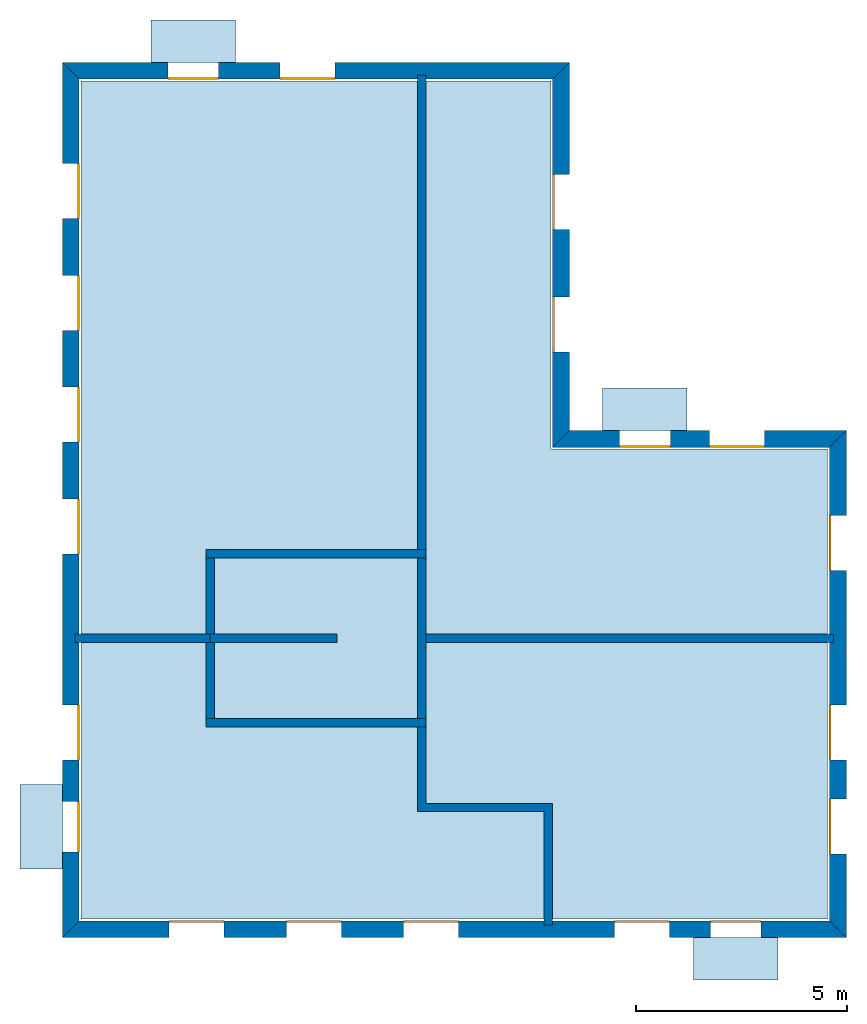
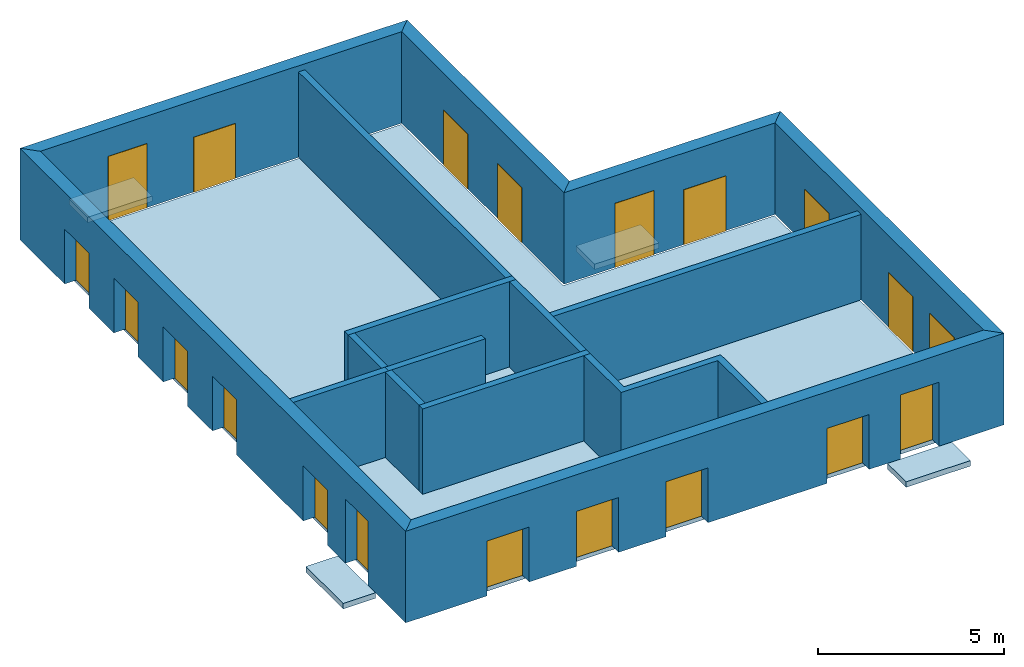
# One storey: 20 windows, 15 walls, 5 slabs, 20 openings.
"""IFC4 building model written with IfcOpenShell, lengths in metres."""

from ifc_helpers import new_model, si_unit, frame, origin_with_axes, place, context, subcontext, project, spatial, line, indexed_curve, outline, extrude, element, fill, save


model = new_model("IFC4")

# Units and contexts
model_context = context("Model", 3, precision=1e-05, world=origin_with_axes())
body_context = subcontext(model_context, "Body", "Model", "MODEL_VIEW")
ifc_project = project(units=[si_unit("AREAUNIT", "SQUARE_METRE"), si_unit("VOLUMEUNIT", "CUBIC_METRE"), si_unit("LENGTHUNIT", "METRE")], contexts=[model_context])

# Site, building, storey
site = spatial("IfcSite", under=ifc_project)
building = spatial("IfcBuilding", under=site, Name="Building 2")
storey_placement = place(None, frame((0.0, 0.0, 4.0), z_axis=(0.0, 0.0, 1.0), x_axis=(1.0, 0.0, 0.0)))
storey = spatial("IfcBuildingStorey", under=building, at=storey_placement, Name="02 Storey")

# Slabs
slab_1_placement = place(storey_placement, origin_with_axes())
element("IfcSlab", 1, at=slab_1_placement, inside=storey, Name="Slab", context=body_context, shape_type="SweptSolid", body=[
    extrude(outline(indexed_curve([(22.099464, -3.599175), (15.553354, -3.599175), (15.553354, 5.1082), (4.433354, 5.1082), (4.433354, -14.719175), (22.099464, -14.719175)], segments=[line(1, 2), line(2, 3), line(3, 4), line(4, 5), line(5, 6)])), origin_with_axes(), (0.0, 0.0, -1.0), 0.2),
])
slab_2_placement = place(storey_placement, origin_with_axes())
element("IfcSlab", 2, at=slab_2_placement, inside=storey, Name="Balcony", context=body_context, shape_type="SweptSolid", body=[
    extrude(outline(indexed_curve([(6.093354, 5.5482), (6.093354, 6.5482), (8.093354, 6.5482), (8.093354, 5.5482)], segments=[line(1, 2), line(2, 3), line(3, 4)])), origin_with_axes(), (0.0, 0.0, -1.0), 0.18),
])
slab_3_placement = place(storey_placement, origin_with_axes())
element("IfcSlab", 3, at=slab_3_placement, inside=storey, Name="Balcony", context=body_context, shape_type="SweptSolid", body=[
    extrude(outline(indexed_curve([(16.7753906666667, -3.159175), (16.7753906666667, -2.159175), (18.7753906666667, -2.159175), (18.7753906666667, -3.159175)], segments=[line(1, 2), line(2, 3), line(3, 4)])), origin_with_axes(), (0.0, 0.0, -1.0), 0.18),
])
slab_4_placement = place(storey_placement, origin_with_axes())
element("IfcSlab", 4, at=slab_4_placement, inside=storey, Name="Balcony", context=body_context, shape_type="SweptSolid", body=[
    extrude(outline(indexed_curve([(20.924094, -15.159175), (20.924094, -16.159175), (18.924094, -16.159175), (18.924094, -15.159175)], segments=[line(1, 2), line(2, 3), line(3, 4)])), origin_with_axes(), (0.0, 0.0, -1.0), 0.18),
])
slab_5_placement = place(storey_placement, origin_with_axes())
element("IfcSlab", 5, at=slab_5_placement, inside=storey, Name="Balcony", context=body_context, shape_type="SweptSolid", body=[
    extrude(outline(indexed_curve([(3.993354, -13.5322976666667), (2.993354, -13.5322976666667), (2.993354, -11.5322976666667), (3.993354, -11.5322976666667)], segments=[line(1, 2), line(2, 3), line(3, 4)])), origin_with_axes(), (0.0, 0.0, -1.0), 0.18),
])

# Walls
wall_1_placement = place(storey_placement, origin_with_axes())
element("IfcWall", 6, at=wall_1_placement, inside=storey, Name="Wall", context=body_context, shape_type="SweptSolid", body=[
    extrude(outline(indexed_curve([(7.593354, -7.978543), (4.293354, -7.978543), (4.293354, -8.178543), (7.593354, -8.178543)], segments=[line(1, 2), line(2, 3), line(3, 4)])), origin_with_axes(), (0.0, 0.0, 1.0), 2.8),
])
wall_2_placement = place(storey_placement, origin_with_axes())
element("IfcWall", 7, at=wall_2_placement, inside=storey, Name="Wall", context=body_context, shape_type="SweptSolid", body=[
    extrude(outline(indexed_curve([(12.593354, 5.2482), (12.393354, 5.2482), (12.393354, -6.178543), (12.593354, -6.178543)], segments=[line(1, 2), line(2, 3), line(3, 4)])), origin_with_axes(), (0.0, 0.0, 1.0), 2.8),
])
wall_3_placement = place(storey_placement, origin_with_axes())
element("IfcWall", 8, at=wall_3_placement, inside=storey, Name="Wall", context=body_context, shape_type="SweptSolid", body=[
    extrude(outline(indexed_curve([(22.239464, -7.978543), (12.393354, -7.978543), (12.393354, -8.178543), (22.239464, -8.178543)], segments=[line(1, 2), line(2, 3), line(3, 4)])), origin_with_axes(), (0.0, 0.0, 1.0), 2.8),
])
wall_4_placement = place(storey_placement, origin_with_axes())
element("IfcWall", 9, at=wall_4_placement, inside=storey, Name="Wall", context=body_context, shape_type="SweptSolid", body=[
    extrude(outline(indexed_curve([(15.593354, -11.978543), (12.593354, -11.978543), (12.593354, -9.978543), (12.393354, -9.978543), (12.393354, -12.178543), (15.393354, -12.178543), (15.393354, -14.859175), (15.593354, -14.859175)], segments=[line(1, 2), line(2, 3), line(3, 4), line(4, 5), line(5, 6), line(6, 7), line(7, 8)])), origin_with_axes(), (0.0, 0.0, 1.0), 2.8),
])

# Wall, openings, windows
wall_5_placement = place(storey_placement, origin_with_axes())
wall_5 = element("IfcWall", 10, at=wall_5_placement, inside=storey, Name="Facade", context=body_context, shape_type="SweptSolid", body=[
    extrude(outline(indexed_curve([(22.139464, -3.559175), (15.593354, -3.559175), (15.993354, -3.159175), (22.539464, -3.159175)], segments=[line(1, 2), line(2, 3), line(3, 4)])), origin_with_axes(), (0.0, 0.0, 1.0), 3.0),
])
opening_1_placement = place(wall_5_placement, origin_with_axes())
opening_1 = element("IfcOpeningElement", 11, at=opening_1_placement, cuts=wall_5, Name="Opening", context=body_context, shape_type="SweptSolid", body=[
    extrude(outline(indexed_curve([(20.6074273333333, -3.119175), (20.6074273333333, -3.619175), (19.3074273333333, -3.619175), (19.3074273333333, -3.119175)], segments=[line(1, 2), line(2, 3), line(3, 4)])), origin_with_axes(), (0.0, 0.0, 1.0), 1.8),
])
opening_2_placement = place(wall_5_placement, origin_with_axes())
opening_2 = element("IfcOpeningElement", 12, at=opening_2_placement, cuts=wall_5, Name="Opening", context=body_context, shape_type="SweptSolid", body=[
    extrude(outline(indexed_curve([(18.3753906666667, -3.119175), (18.3753906666667, -3.619175), (17.1753906666667, -3.619175), (17.1753906666667, -3.119175)], segments=[line(1, 2), line(2, 3), line(3, 4)])), origin_with_axes(), (0.0, 0.0, 1.0), 2.1),
])
window_1_placement = place(storey_placement, origin_with_axes())
window_1 = element("IfcWindow", 13, at=window_1_placement, inside=storey, Name="Window", PredefinedType="WINDOW", context=body_context, shape_type="SweptSolid", body=[
    extrude(outline(indexed_curve([(20.6074273333333, -3.519175), (20.6074273333333, -3.569175), (19.3074273333333, -3.569175), (19.3074273333333, -3.519175)], segments=[line(1, 2), line(2, 3), line(3, 4)])), origin_with_axes(), (0.0, 0.0, 1.0), 1.8),
])
fill(opening_1, window_1)
window_2_placement = place(storey_placement, origin_with_axes())
window_2 = element("IfcWindow", 14, at=window_2_placement, inside=storey, Name="Window", PredefinedType="WINDOW", context=body_context, shape_type="SweptSolid", body=[
    extrude(outline(indexed_curve([(18.3753906666667, -3.519175), (18.3753906666667, -3.569175), (17.1753906666667, -3.569175), (17.1753906666667, -3.519175)], segments=[line(1, 2), line(2, 3), line(3, 4)])), origin_with_axes(), (0.0, 0.0, 1.0), 2.1),
])
fill(opening_2, window_2)

wall_6_placement = place(storey_placement, origin_with_axes())
wall_6 = element("IfcWall", 15, at=wall_6_placement, inside=storey, Name="Facade", context=body_context, shape_type="SweptSolid", body=[
    extrude(outline(indexed_curve([(15.593354, -3.559175), (15.593354, 5.1482), (15.993354, 5.5482), (15.993354, -3.159175)], segments=[line(1, 2), line(2, 3), line(3, 4)])), origin_with_axes(), (0.0, 0.0, 1.0), 3.0),
])
opening_3_placement = place(wall_6_placement, origin_with_axes())
opening_3 = element("IfcOpeningElement", 16, at=opening_3_placement, cuts=wall_6, Name="Opening", context=body_context, shape_type="SweptSolid", body=[
    extrude(outline(indexed_curve([(16.033354, -1.30671666666667), (15.533354, -1.30671666666667), (15.533354, -0.00671666666666659), (16.033354, -0.00671666666666659)], segments=[line(1, 2), line(2, 3), line(3, 4)])), origin_with_axes(), (0.0, 0.0, 1.0), 1.8),
])
opening_4_placement = place(wall_6_placement, origin_with_axes())
opening_4 = element("IfcOpeningElement", 17, at=opening_4_placement, cuts=wall_6, Name="Opening", context=body_context, shape_type="SweptSolid", body=[
    extrude(outline(indexed_curve([(16.033354, 1.59574166666667), (15.533354, 1.59574166666667), (15.533354, 2.89574166666667), (16.033354, 2.89574166666667)], segments=[line(1, 2), line(2, 3), line(3, 4)])), origin_with_axes(), (0.0, 0.0, 1.0), 1.8),
])
window_3_placement = place(storey_placement, origin_with_axes())
window_3 = element("IfcWindow", 18, at=window_3_placement, inside=storey, Name="Window", PredefinedType="WINDOW", context=body_context, shape_type="SweptSolid", body=[
    extrude(outline(indexed_curve([(15.633354, -1.30671666666667), (15.583354, -1.30671666666667), (15.583354, -0.00671666666666659), (15.633354, -0.00671666666666659)], segments=[line(1, 2), line(2, 3), line(3, 4)])), origin_with_axes(), (0.0, 0.0, 1.0), 1.8),
])
fill(opening_3, window_3)
window_4_placement = place(storey_placement, origin_with_axes())
window_4 = element("IfcWindow", 19, at=window_4_placement, inside=storey, Name="Window", PredefinedType="WINDOW", context=body_context, shape_type="SweptSolid", body=[
    extrude(outline(indexed_curve([(15.633354, 1.59574166666667), (15.583354, 1.59574166666667), (15.583354, 2.89574166666667), (15.633354, 2.89574166666667)], segments=[line(1, 2), line(2, 3), line(3, 4)])), origin_with_axes(), (0.0, 0.0, 1.0), 1.8),
])
fill(opening_4, window_4)

wall_7_placement = place(storey_placement, origin_with_axes())
wall_7 = element("IfcWall", 20, at=wall_7_placement, inside=storey, Name="Facade", context=body_context, shape_type="SweptSolid", body=[
    extrude(outline(indexed_curve([(15.593354, 5.1482), (4.393354, 5.1482), (3.993354, 5.5482), (15.993354, 5.5482)], segments=[line(1, 2), line(2, 3), line(3, 4)])), origin_with_axes(), (0.0, 0.0, 1.0), 3.0),
])
opening_5_placement = place(wall_7_placement, origin_with_axes())
opening_5 = element("IfcOpeningElement", 21, at=opening_5_placement, cuts=wall_7, Name="Opening", context=body_context, shape_type="SweptSolid", body=[
    extrude(outline(indexed_curve([(10.443354, 5.5882), (10.443354, 5.0882), (9.143354, 5.0882), (9.143354, 5.5882)], segments=[line(1, 2), line(2, 3), line(3, 4)])), origin_with_axes(), (0.0, 0.0, 1.0), 1.8),
])
opening_6_placement = place(wall_7_placement, origin_with_axes())
opening_6 = element("IfcOpeningElement", 22, at=opening_6_placement, cuts=wall_7, Name="Opening", context=body_context, shape_type="SweptSolid", body=[
    extrude(outline(indexed_curve([(7.693354, 5.5882), (7.693354, 5.0882), (6.493354, 5.0882), (6.493354, 5.5882)], segments=[line(1, 2), line(2, 3), line(3, 4)])), origin_with_axes(), (0.0, 0.0, 1.0), 2.1),
])
window_5_placement = place(storey_placement, origin_with_axes())
window_5 = element("IfcWindow", 23, at=window_5_placement, inside=storey, Name="Window", PredefinedType="WINDOW", context=body_context, shape_type="SweptSolid", body=[
    extrude(outline(indexed_curve([(10.443354, 5.1882), (10.443354, 5.1382), (9.143354, 5.1382), (9.143354, 5.1882)], segments=[line(1, 2), line(2, 3), line(3, 4)])), origin_with_axes(), (0.0, 0.0, 1.0), 1.8),
])
fill(opening_5, window_5)
window_6_placement = place(storey_placement, origin_with_axes())
window_6 = element("IfcWindow", 24, at=window_6_placement, inside=storey, Name="Window", PredefinedType="WINDOW", context=body_context, shape_type="SweptSolid", body=[
    extrude(outline(indexed_curve([(7.693354, 5.1882), (7.693354, 5.1382), (6.493354, 5.1382), (6.493354, 5.1882)], segments=[line(1, 2), line(2, 3), line(3, 4)])), origin_with_axes(), (0.0, 0.0, 1.0), 2.1),
])
fill(opening_6, window_6)

wall_8_placement = place(storey_placement, origin_with_axes())
wall_8 = element("IfcWall", 25, at=wall_8_placement, inside=storey, Name="Facade", context=body_context, shape_type="SweptSolid", body=[
    extrude(outline(indexed_curve([(4.393354, 5.1482), (4.393354, -14.759175), (3.993354, -15.159175), (3.993354, 5.5482)], segments=[line(1, 2), line(2, 3), line(3, 4)])), origin_with_axes(), (0.0, 0.0, 1.0), 3.0),
])
opening_7_placement = place(wall_8_placement, origin_with_axes())
opening_7 = element("IfcOpeningElement", 26, at=opening_7_placement, cuts=wall_8, Name="Opening", context=body_context, shape_type="SweptSolid", body=[
    extrude(outline(indexed_curve([(3.953354, 3.1528514), (4.453354, 3.1528514), (4.453354, 1.8528514), (3.953354, 1.8528514)], segments=[line(1, 2), line(2, 3), line(3, 4)])), origin_with_axes(), (0.0, 0.0, 1.0), 1.8),
])
opening_8_placement = place(wall_8_placement, origin_with_axes())
opening_8 = element("IfcOpeningElement", 27, at=opening_8_placement, cuts=wall_8, Name="Opening", context=body_context, shape_type="SweptSolid", body=[
    extrude(outline(indexed_curve([(3.953354, 0.507502800000001), (4.453354, 0.507502800000001), (4.453354, -0.792497199999999), (3.953354, -0.792497199999999)], segments=[line(1, 2), line(2, 3), line(3, 4)])), origin_with_axes(), (0.0, 0.0, 1.0), 1.8),
])
opening_9_placement = place(wall_8_placement, origin_with_axes())
opening_9 = element("IfcOpeningElement", 28, at=opening_9_placement, cuts=wall_8, Name="Opening", context=body_context, shape_type="SweptSolid", body=[
    extrude(outline(indexed_curve([(3.953354, -2.1378458), (4.453354, -2.1378458), (4.453354, -3.4378458), (3.953354, -3.4378458)], segments=[line(1, 2), line(2, 3), line(3, 4)])), origin_with_axes(), (0.0, 0.0, 1.0), 1.8),
])
opening_10_placement = place(wall_8_placement, origin_with_axes())
opening_10 = element("IfcOpeningElement", 29, at=opening_10_placement, cuts=wall_8, Name="Opening", context=body_context, shape_type="SweptSolid", body=[
    extrude(outline(indexed_curve([(3.953354, -4.7831944), (4.453354, -4.7831944), (4.453354, -6.0831944), (3.953354, -6.0831944)], segments=[line(1, 2), line(2, 3), line(3, 4)])), origin_with_axes(), (0.0, 0.0, 1.0), 1.8),
])
opening_11_placement = place(wall_8_placement, origin_with_axes())
opening_11 = element("IfcOpeningElement", 30, at=opening_11_placement, cuts=wall_8, Name="Opening", context=body_context, shape_type="SweptSolid", body=[
    extrude(outline(indexed_curve([(3.953354, -9.65542033333333), (4.453354, -9.65542033333333), (4.453354, -10.9554203333333), (3.953354, -10.9554203333333)], segments=[line(1, 2), line(2, 3), line(3, 4)])), origin_with_axes(), (0.0, 0.0, 1.0), 1.8),
])
opening_12_placement = place(wall_8_placement, origin_with_axes())
opening_12 = element("IfcOpeningElement", 31, at=opening_12_placement, cuts=wall_8, Name="Opening", context=body_context, shape_type="SweptSolid", body=[
    extrude(outline(indexed_curve([(3.953354, -11.9322976666667), (4.453354, -11.9322976666667), (4.453354, -13.1322976666667), (3.953354, -13.1322976666667)], segments=[line(1, 2), line(2, 3), line(3, 4)])), origin_with_axes(), (0.0, 0.0, 1.0), 2.1),
])
window_7_placement = place(storey_placement, origin_with_axes())
window_7 = element("IfcWindow", 32, at=window_7_placement, inside=storey, Name="Window", PredefinedType="WINDOW", context=body_context, shape_type="SweptSolid", body=[
    extrude(outline(indexed_curve([(4.353354, 3.1528514), (4.403354, 3.1528514), (4.403354, 1.8528514), (4.353354, 1.8528514)], segments=[line(1, 2), line(2, 3), line(3, 4)])), origin_with_axes(), (0.0, 0.0, 1.0), 1.8),
])
fill(opening_7, window_7)
window_8_placement = place(storey_placement, origin_with_axes())
window_8 = element("IfcWindow", 33, at=window_8_placement, inside=storey, Name="Window", PredefinedType="WINDOW", context=body_context, shape_type="SweptSolid", body=[
    extrude(outline(indexed_curve([(4.353354, 0.507502800000001), (4.403354, 0.507502800000001), (4.403354, -0.792497199999999), (4.353354, -0.792497199999999)], segments=[line(1, 2), line(2, 3), line(3, 4)])), origin_with_axes(), (0.0, 0.0, 1.0), 1.8),
])
fill(opening_8, window_8)
window_9_placement = place(storey_placement, origin_with_axes())
window_9 = element("IfcWindow", 34, at=window_9_placement, inside=storey, Name="Window", PredefinedType="WINDOW", context=body_context, shape_type="SweptSolid", body=[
    extrude(outline(indexed_curve([(4.353354, -2.1378458), (4.403354, -2.1378458), (4.403354, -3.4378458), (4.353354, -3.4378458)], segments=[line(1, 2), line(2, 3), line(3, 4)])), origin_with_axes(), (0.0, 0.0, 1.0), 1.8),
])
fill(opening_9, window_9)
window_10_placement = place(storey_placement, origin_with_axes())
window_10 = element("IfcWindow", 35, at=window_10_placement, inside=storey, Name="Window", PredefinedType="WINDOW", context=body_context, shape_type="SweptSolid", body=[
    extrude(outline(indexed_curve([(4.353354, -4.7831944), (4.403354, -4.7831944), (4.403354, -6.0831944), (4.353354, -6.0831944)], segments=[line(1, 2), line(2, 3), line(3, 4)])), origin_with_axes(), (0.0, 0.0, 1.0), 1.8),
])
fill(opening_10, window_10)
window_11_placement = place(storey_placement, origin_with_axes())
window_11 = element("IfcWindow", 36, at=window_11_placement, inside=storey, Name="Window", PredefinedType="WINDOW", context=body_context, shape_type="SweptSolid", body=[
    extrude(outline(indexed_curve([(4.353354, -9.65542033333333), (4.403354, -9.65542033333333), (4.403354, -10.9554203333333), (4.353354, -10.9554203333333)], segments=[line(1, 2), line(2, 3), line(3, 4)])), origin_with_axes(), (0.0, 0.0, 1.0), 1.8),
])
fill(opening_11, window_11)
window_12_placement = place(storey_placement, origin_with_axes())
window_12 = element("IfcWindow", 37, at=window_12_placement, inside=storey, Name="Window", PredefinedType="WINDOW", context=body_context, shape_type="SweptSolid", body=[
    extrude(outline(indexed_curve([(4.353354, -11.9322976666667), (4.403354, -11.9322976666667), (4.403354, -13.1322976666667), (4.353354, -13.1322976666667)], segments=[line(1, 2), line(2, 3), line(3, 4)])), origin_with_axes(), (0.0, 0.0, 1.0), 2.1),
])
fill(opening_12, window_12)

wall_9_placement = place(storey_placement, origin_with_axes())
wall_9 = element("IfcWall", 38, at=wall_9_placement, inside=storey, Name="Facade", context=body_context, shape_type="SweptSolid", body=[
    extrude(outline(indexed_curve([(4.393354, -14.759175), (22.139464, -14.759175), (22.539464, -15.159175), (3.993354, -15.159175)], segments=[line(1, 2), line(2, 3), line(3, 4)])), origin_with_axes(), (0.0, 0.0, 1.0), 3.0),
])
opening_13_placement = place(wall_9_placement, origin_with_axes())
opening_13 = element("IfcOpeningElement", 39, at=opening_13_placement, cuts=wall_9, Name="Opening", context=body_context, shape_type="SweptSolid", body=[
    extrude(outline(indexed_curve([(17.058724, -15.199175), (17.058724, -14.699175), (18.358724, -14.699175), (18.358724, -15.199175)], segments=[line(1, 2), line(2, 3), line(3, 4)])), origin_with_axes(), (0.0, 0.0, 1.0), 1.8),
])
opening_14_placement = place(wall_9_placement, origin_with_axes())
opening_14 = element("IfcOpeningElement", 40, at=opening_14_placement, cuts=wall_9, Name="Opening", context=body_context, shape_type="SweptSolid", body=[
    extrude(outline(indexed_curve([(19.324094, -15.199175), (19.324094, -14.699175), (20.524094, -14.699175), (20.524094, -15.199175)], segments=[line(1, 2), line(2, 3), line(3, 4)])), origin_with_axes(), (0.0, 0.0, 1.0), 2.1),
])
opening_15_placement = place(wall_9_placement, origin_with_axes())
opening_15 = element("IfcOpeningElement", 41, at=opening_15_placement, cuts=wall_9, Name="Opening", context=body_context, shape_type="SweptSolid", body=[
    extrude(outline(indexed_curve([(6.518354, -15.199175), (6.518354, -14.699175), (7.818354, -14.699175), (7.818354, -15.199175)], segments=[line(1, 2), line(2, 3), line(3, 4)])), origin_with_axes(), (0.0, 0.0, 1.0), 1.8),
])
opening_16_placement = place(wall_9_placement, origin_with_axes())
opening_16 = element("IfcOpeningElement", 42, at=opening_16_placement, cuts=wall_9, Name="Opening", context=body_context, shape_type="SweptSolid", body=[
    extrude(outline(indexed_curve([(9.293354, -15.199175), (9.293354, -14.699175), (10.593354, -14.699175), (10.593354, -15.199175)], segments=[line(1, 2), line(2, 3), line(3, 4)])), origin_with_axes(), (0.0, 0.0, 1.0), 1.8),
])
opening_17_placement = place(wall_9_placement, origin_with_axes())
opening_17 = element("IfcOpeningElement", 43, at=opening_17_placement, cuts=wall_9, Name="Opening", context=body_context, shape_type="SweptSolid", body=[
    extrude(outline(indexed_curve([(12.068354, -15.199175), (12.068354, -14.699175), (13.368354, -14.699175), (13.368354, -15.199175)], segments=[line(1, 2), line(2, 3), line(3, 4)])), origin_with_axes(), (0.0, 0.0, 1.0), 1.8),
])
window_13_placement = place(storey_placement, origin_with_axes())
window_13 = element("IfcWindow", 44, at=window_13_placement, inside=storey, Name="Window", PredefinedType="WINDOW", context=body_context, shape_type="SweptSolid", body=[
    extrude(outline(indexed_curve([(17.058724, -14.799175), (17.058724, -14.749175), (18.358724, -14.749175), (18.358724, -14.799175)], segments=[line(1, 2), line(2, 3), line(3, 4)])), origin_with_axes(), (0.0, 0.0, 1.0), 1.8),
])
fill(opening_13, window_13)
window_14_placement = place(storey_placement, origin_with_axes())
window_14 = element("IfcWindow", 45, at=window_14_placement, inside=storey, Name="Window", PredefinedType="WINDOW", context=body_context, shape_type="SweptSolid", body=[
    extrude(outline(indexed_curve([(19.324094, -14.799175), (19.324094, -14.749175), (20.524094, -14.749175), (20.524094, -14.799175)], segments=[line(1, 2), line(2, 3), line(3, 4)])), origin_with_axes(), (0.0, 0.0, 1.0), 2.1),
])
fill(opening_14, window_14)
window_15_placement = place(storey_placement, origin_with_axes())
window_15 = element("IfcWindow", 46, at=window_15_placement, inside=storey, Name="Window", PredefinedType="WINDOW", context=body_context, shape_type="SweptSolid", body=[
    extrude(outline(indexed_curve([(6.518354, -14.799175), (6.518354, -14.749175), (7.818354, -14.749175), (7.818354, -14.799175)], segments=[line(1, 2), line(2, 3), line(3, 4)])), origin_with_axes(), (0.0, 0.0, 1.0), 1.8),
])
fill(opening_15, window_15)
window_16_placement = place(storey_placement, origin_with_axes())
window_16 = element("IfcWindow", 47, at=window_16_placement, inside=storey, Name="Window", PredefinedType="WINDOW", context=body_context, shape_type="SweptSolid", body=[
    extrude(outline(indexed_curve([(9.293354, -14.799175), (9.293354, -14.749175), (10.593354, -14.749175), (10.593354, -14.799175)], segments=[line(1, 2), line(2, 3), line(3, 4)])), origin_with_axes(), (0.0, 0.0, 1.0), 1.8),
])
fill(opening_16, window_16)
window_17_placement = place(storey_placement, origin_with_axes())
window_17 = element("IfcWindow", 48, at=window_17_placement, inside=storey, Name="Window", PredefinedType="WINDOW", context=body_context, shape_type="SweptSolid", body=[
    extrude(outline(indexed_curve([(12.068354, -14.799175), (12.068354, -14.749175), (13.368354, -14.749175), (13.368354, -14.799175)], segments=[line(1, 2), line(2, 3), line(3, 4)])), origin_with_axes(), (0.0, 0.0, 1.0), 1.8),
])
fill(opening_17, window_17)

wall_10_placement = place(storey_placement, origin_with_axes())
wall_10 = element("IfcWall", 49, at=wall_10_placement, inside=storey, Name="Facade", context=body_context, shape_type="SweptSolid", body=[
    extrude(outline(indexed_curve([(22.139464, -14.759175), (22.139464, -3.559175), (22.539464, -3.159175), (22.539464, -15.159175)], segments=[line(1, 2), line(2, 3), line(3, 4)])), origin_with_axes(), (0.0, 0.0, 1.0), 3.0),
])
opening_18_placement = place(wall_10_placement, origin_with_axes())
opening_18 = element("IfcOpeningElement", 50, at=opening_18_placement, cuts=wall_10, Name="Opening", context=body_context, shape_type="SweptSolid", body=[
    extrude(outline(indexed_curve([(22.579464, -6.468859), (22.079464, -6.468859), (22.079464, -5.168859), (22.579464, -5.168859)], segments=[line(1, 2), line(2, 3), line(3, 4)])), origin_with_axes(), (0.0, 0.0, 1.0), 1.8),
])
opening_19_placement = place(wall_10_placement, origin_with_axes())
opening_19 = element("IfcOpeningElement", 51, at=opening_19_placement, cuts=wall_10, Name="Opening", context=body_context, shape_type="SweptSolid", body=[
    extrude(outline(indexed_curve([(22.579464, -13.1822976666667), (22.079464, -13.1822976666667), (22.079464, -11.8822976666667), (22.579464, -11.8822976666667)], segments=[line(1, 2), line(2, 3), line(3, 4)])), origin_with_axes(), (0.0, 0.0, 1.0), 1.8),
])
opening_20_placement = place(wall_10_placement, origin_with_axes())
opening_20 = element("IfcOpeningElement", 52, at=opening_20_placement, cuts=wall_10, Name="Opening", context=body_context, shape_type="SweptSolid", body=[
    extrude(outline(indexed_curve([(22.579464, -10.9554203333333), (22.079464, -10.9554203333333), (22.079464, -9.65542033333333), (22.579464, -9.65542033333333)], segments=[line(1, 2), line(2, 3), line(3, 4)])), origin_with_axes(), (0.0, 0.0, 1.0), 1.8),
])
window_18_placement = place(storey_placement, origin_with_axes())
window_18 = element("IfcWindow", 53, at=window_18_placement, inside=storey, Name="Window", PredefinedType="WINDOW", context=body_context, shape_type="SweptSolid", body=[
    extrude(outline(indexed_curve([(22.179464, -6.468859), (22.129464, -6.468859), (22.129464, -5.168859), (22.179464, -5.168859)], segments=[line(1, 2), line(2, 3), line(3, 4)])), origin_with_axes(), (0.0, 0.0, 1.0), 1.8),
])
fill(opening_18, window_18)
window_19_placement = place(storey_placement, origin_with_axes())
window_19 = element("IfcWindow", 54, at=window_19_placement, inside=storey, Name="Window", PredefinedType="WINDOW", context=body_context, shape_type="SweptSolid", body=[
    extrude(outline(indexed_curve([(22.179464, -13.1822976666667), (22.129464, -13.1822976666667), (22.129464, -11.8822976666667), (22.179464, -11.8822976666667)], segments=[line(1, 2), line(2, 3), line(3, 4)])), origin_with_axes(), (0.0, 0.0, 1.0), 1.8),
])
fill(opening_19, window_19)
window_20_placement = place(storey_placement, origin_with_axes())
window_20 = element("IfcWindow", 55, at=window_20_placement, inside=storey, Name="Window", PredefinedType="WINDOW", context=body_context, shape_type="SweptSolid", body=[
    extrude(outline(indexed_curve([(22.179464, -10.9554203333333), (22.129464, -10.9554203333333), (22.129464, -9.65542033333333), (22.179464, -9.65542033333333)], segments=[line(1, 2), line(2, 3), line(3, 4)])), origin_with_axes(), (0.0, 0.0, 1.0), 1.8),
])
fill(opening_20, window_20)

# Walls
wall_11_placement = place(storey_placement, origin_with_axes())
element("IfcWall", 56, at=wall_11_placement, inside=storey, Name="CoreWall", context=body_context, shape_type="SweptSolid", body=[
    extrude(outline(indexed_curve([(12.593354, -5.978543), (7.393354, -5.978543), (7.393354, -6.178543), (12.593354, -6.178543)], segments=[line(1, 2), line(2, 3), line(3, 4)])), origin_with_axes(), (0.0, 0.0, 1.0), 2.8),
])
wall_12_placement = place(storey_placement, origin_with_axes())
element("IfcWall", 57, at=wall_12_placement, inside=storey, Name="CoreWall", context=body_context, shape_type="SweptSolid", body=[
    extrude(outline(indexed_curve([(7.393354, -10.178543), (12.593354, -10.178543), (12.593354, -9.978543), (7.393354, -9.978543)], segments=[line(1, 2), line(2, 3), line(3, 4)])), origin_with_axes(), (0.0, 0.0, 1.0), 2.8),
])
wall_13_placement = place(storey_placement, origin_with_axes())
element("IfcWall", 58, at=wall_13_placement, inside=storey, Name="CoreWall", context=body_context, shape_type="SweptSolid", body=[
    extrude(outline(indexed_curve([(7.593354, -9.978543), (7.593354, -6.178543), (7.393354, -6.178543), (7.393354, -9.978543)], segments=[line(1, 2), line(2, 3), line(3, 4)])), origin_with_axes(), (0.0, 0.0, 1.0), 2.8),
])
wall_14_placement = place(storey_placement, origin_with_axes())
element("IfcWall", 59, at=wall_14_placement, inside=storey, Name="CoreWall", context=body_context, shape_type="SweptSolid", body=[
    extrude(outline(indexed_curve([(12.393354, -6.178543), (12.393354, -9.978543), (12.593354, -9.978543), (12.593354, -6.178543)], segments=[line(1, 2), line(2, 3), line(3, 4)])), origin_with_axes(), (0.0, 0.0, 1.0), 2.8),
])
wall_15_placement = place(storey_placement, origin_with_axes())
element("IfcWall", 60, at=wall_15_placement, inside=storey, Name="CoreWall", context=body_context, shape_type="SweptSolid", body=[
    extrude(outline(indexed_curve([(10.493354, -7.978543), (7.493354, -7.978543), (7.493354, -8.178543), (10.493354, -8.178543)], segments=[line(1, 2), line(2, 3), line(3, 4)])), origin_with_axes(), (0.0, 0.0, 1.0), 2.8),
])

save(model, "model.ifc")
